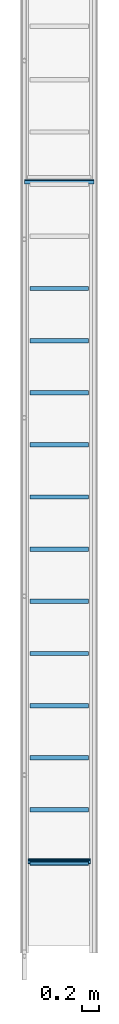
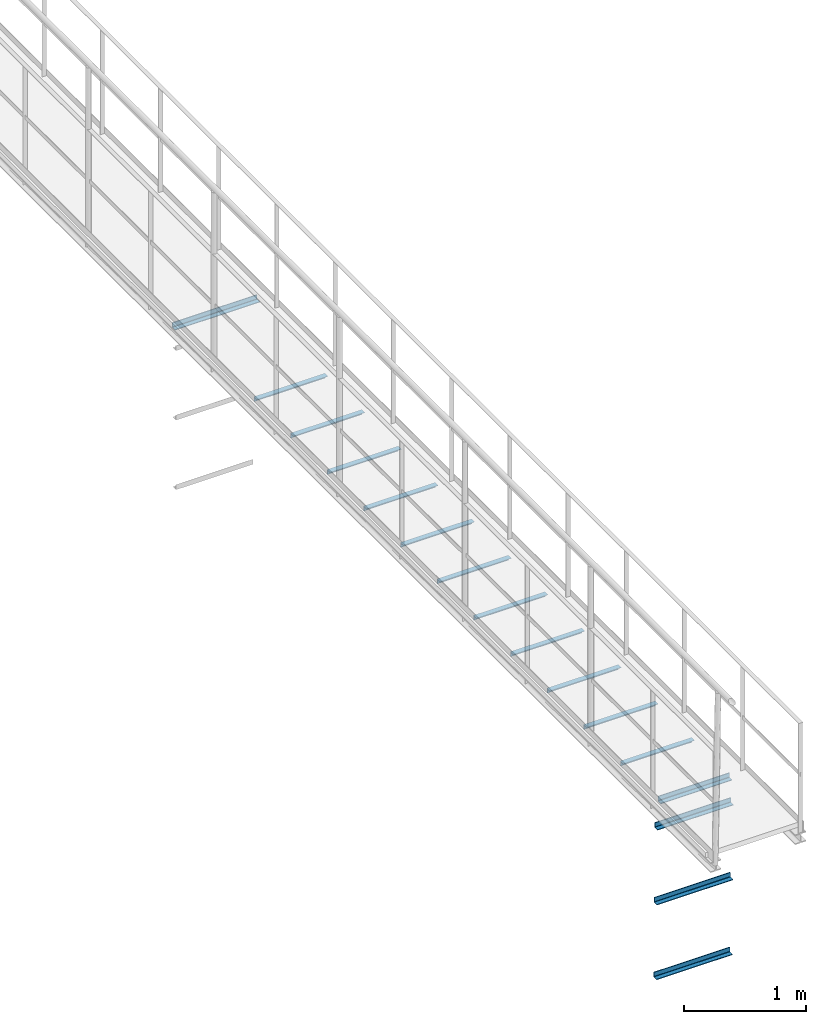
# One storey, part 4 of 6: 11 beams, 5 members.
"""IFC2X3 building model written with IfcOpenShell, lengths in metres."""

from ifc_helpers import new_model, entity, si_unit, converted_unit, derived_unit, direction, frame, frame_2d, origin, place, context, subcontext, project, spatial, polyline, circle_curve, parameter, trimmed, segment, composite_curve, outline, extrude, source, transform, mapped, material, type_object, type_shapes, element, save


model = new_model("IFC2X3")

# Units and contexts
model_context = context("Model", 3, precision=1e-05, world=origin(), true_north=direction((6.123233995736766e-17, 1.0)))
body_context = subcontext(model_context, "Body", "Model", "MODEL_VIEW")
ifc_project = project(units=[si_unit("LENGTHUNIT", "METRE"), converted_unit("PLANEANGLEUNIT", "DEGREE", entity("IfcPlaneAngleMeasure", 0.017453292519943278), si_unit("PLANEANGLEUNIT", "RADIAN"), dimensions=[0, 0, 0, 0, 0, 0, 0]), si_unit("AREAUNIT", "SQUARE_METRE"), derived_unit("THERMALTRANSMITTANCEUNIT", [(si_unit("MASSUNIT", "GRAM", prefix="KILO"), 1), (si_unit("THERMODYNAMICTEMPERATUREUNIT", "KELVIN"), -1), (si_unit("TIMEUNIT", "SECOND"), -3)])], contexts=[model_context])

# Site, building, storey
site_placement = place(None, origin())
site = spatial("IfcSite", under=ifc_project, at=site_placement, CompositionType="ELEMENT")
building_placement = place(site_placement, origin())
building = spatial("IfcBuilding", under=site, at=building_placement, CompositionType="ELEMENT")
storey_placement = place(building_placement, frame((0.0, 0.0, 8.8)))
storey = spatial("IfcBuildingStorey", under=building, at=storey_placement, Name="Piso 2.3", CompositionType="ELEMENT", Elevation=8.8)

# Members
ifc_material = material(Name="Metal - Steel - 345 MPa")
member_type_1 = type_object("IfcMemberType", Name="L-Angles:CAE50x5", PredefinedType="BRACE", material=ifc_material)
shared_shape_1 = source(origin(), body_context, "Body", "SweptSolid", [
    extrude(outline(composite_curve([segment(polyline([(-0.016428571428572104, -0.016428571428570952), (0.03357142857143008, -0.016428571428570952)]), True, "CONTINUOUS"), segment(trimmed(circle_curve(frame_2d((0.02857142857143008, -0.016428571428571702), x_axis=(1.0, 0.0)), 0.005), [parameter(5.088887490341632e-14)], [parameter(90.00000000000009)], True, "PARAMETER"), True, "CONTINUOUS"), segment(polyline([(0.02857142857143009, -0.011428571428571706), (-0.006428571428571976, -0.011428571428571706)]), True, "CONTINUOUS"), segment(trimmed(circle_curve(frame_2d((-0.006428571428571986, -0.006428571428571703), x_axis=(1.0, 0.0)), 0.005), [parameter(180.00000000000017)], [parameter(269.9999999999999)], True, "PARAMETER"), False, "CONTINUOUS"), segment(polyline([(-0.011428571428571985, -0.006428571428571719), (-0.011428571428571985, 0.02857142857142889)]), True, "CONTINUOUS"), segment(trimmed(circle_curve(frame_2d((-0.016428571428571986, 0.02857142857142889), x_axis=(1.0, 0.0)), 0.005), [parameter(0.0)], [parameter(90.00000000000024)], True, "PARAMETER"), True, "CONTINUOUS"), segment(polyline([(-0.016428571428572104, 0.03357142857142889), (-0.016428571428572104, -0.01642857142857095)]), True, "CONTINUOUS")], self_intersect=False)), frame((-0.337, -0.0024285714285723395, -0.0024285714285764517), z_axis=(1.0, 0.0, 0.0), x_axis=(0.0, -1.0, 0.0)), (0.0, 0.0, 1.0), 0.674),
])
type_shapes(member_type_1, [shared_shape_1])
member_1_placement = place(storey_placement, frame((4.1066971351921495, -3.3204777675637764, 0.0), z_axis=(0.0, 1.0, 0.0), x_axis=(1.0, 0.0, 0.0)))
element("IfcMember", 1, at=member_1_placement, inside=storey, type_object=member_type_1, material=ifc_material, Name="L-Angles:CAE50x5", ObjectType="L-Angles:CAE50x5", context=body_context, shape_type="MappedRepresentation", body=[
    mapped(shared_shape_1, transform((0.0, 0.0, 0.0), scale=1.0)),
])
member_type_2 = type_object("IfcMemberType", Name="L-Angles:CAE50x5", PredefinedType="BRACE", material=ifc_material)
shared_shape_2 = source(origin(), body_context, "Body", "SweptSolid", [
    extrude(outline(composite_curve([segment(polyline([(-0.016428571428572104, -0.016428571428570952), (0.03357142857143008, -0.016428571428570952)]), True, "CONTINUOUS"), segment(trimmed(circle_curve(frame_2d((0.02857142857143008, -0.016428571428571702), x_axis=(1.0, 0.0)), 0.005), [parameter(5.088887490341632e-14)], [parameter(90.00000000000009)], True, "PARAMETER"), True, "CONTINUOUS"), segment(polyline([(0.02857142857143009, -0.011428571428571706), (-0.006428571428571976, -0.011428571428571706)]), True, "CONTINUOUS"), segment(trimmed(circle_curve(frame_2d((-0.006428571428571986, -0.006428571428571703), x_axis=(1.0, 0.0)), 0.005), [parameter(180.00000000000017)], [parameter(269.9999999999999)], True, "PARAMETER"), False, "CONTINUOUS"), segment(polyline([(-0.011428571428571985, -0.006428571428571719), (-0.011428571428571985, 0.02857142857142889)]), True, "CONTINUOUS"), segment(trimmed(circle_curve(frame_2d((-0.016428571428571986, 0.02857142857142889), x_axis=(1.0, 0.0)), 0.005), [parameter(0.0)], [parameter(90.00000000000024)], True, "PARAMETER"), True, "CONTINUOUS"), segment(polyline([(-0.016428571428572104, 0.03357142857142889), (-0.016428571428572104, -0.01642857142857095)]), True, "CONTINUOUS")], self_intersect=False)), frame((-0.4, -0.0024285714285723395, -0.0024285714285764517), z_axis=(1.0, 0.0, 0.0), x_axis=(0.0, -1.0, 0.0)), (0.0, 0.0, 1.0), 0.8),
])
type_shapes(member_type_2, [shared_shape_2])
member_2_placement = place(storey_placement, frame((4.106697135192162, 4.519522232436223, 0.0), z_axis=(0.0, 1.0, 0.0), x_axis=(1.0, 0.0, 0.0)))
element("IfcMember", 2, at=member_2_placement, inside=storey, type_object=member_type_2, material=ifc_material, Name="L-Angles:CAE50x5", ObjectType="L-Angles:CAE50x5", context=body_context, shape_type="MappedRepresentation", body=[
    mapped(shared_shape_2, transform((0.0, 0.0, 0.0), scale=1.0)),
])

# Beams
beam_type = type_object("IfcBeamType", Name="L-Angles:CAE50x5", PredefinedType="BEAM")
beam_1_placement = place(storey_placement, frame((3.7066971351921265, -2.706477767563773, 0.0)))
element("IfcBeam", 3, at=beam_1_placement, inside=storey, type_object=beam_type, material=ifc_material, Name="L-Angles:CAE50x5", ObjectType="L-Angles:CAE50x5", context=body_context, shape_type="SweptSolid", body=[
    extrude(outline(composite_curve([segment(polyline([(-0.033571428571429786, -0.01642857142857166), (0.016428571428569683, -0.01642857142857166)]), True, "CONTINUOUS"), segment(polyline([(0.016428571428569683, -0.0164285714285722), (0.016428571428570224, 0.03357142857143051)]), True, "CONTINUOUS"), segment(trimmed(circle_curve(frame_2d((0.01642857142857017, 0.02857142857143002), x_axis=(0.0, 1.0)), 0.004999999999999386), [parameter(0.0)], [parameter(90.0000000000187)], True, "PARAMETER"), True, "CONTINUOUS"), segment(polyline([(0.011428571428571305, 0.02857142857142953), (0.011428571428570927, -0.006428571428572257)]), True, "CONTINUOUS"), segment(trimmed(circle_curve(frame_2d((0.00642857142857098, -0.006428571428572743), x_axis=(1.0, 0.0)), 0.004999999999999392), [parameter(269.9999999999813)], [parameter(0.0)], True, "PARAMETER"), False, "CONTINUOUS"), segment(polyline([(0.006428571428569843, -0.011428571428572148), (-0.028571428571430864, -0.011428571428571229)]), True, "CONTINUOUS"), segment(trimmed(circle_curve(frame_2d((-0.028571428571429833, -0.016428571428571716), x_axis=(0.0, 1.0)), 0.0049999999999998075), [parameter(0.0)], [parameter(90.00000000000009)], True, "PARAMETER"), True, "CONTINUOUS")], self_intersect=False)), frame((0.06300000000002301, -0.002428571428571418, -0.002428571428575208), z_axis=(1.0, 0.0, 0.0), x_axis=(0.0, 0.0, 1.0)), (0.0, 0.0, 1.0), 0.6740000000000007),
])
beam_2_placement = place(storey_placement, frame((3.706697135192128, -2.106477767563773, 0.0)))
element("IfcBeam", 4, at=beam_2_placement, inside=storey, type_object=beam_type, material=ifc_material, Name="L-Angles:CAE50x5", ObjectType="L-Angles:CAE50x5", context=body_context, shape_type="SweptSolid", body=[
    extrude(outline(composite_curve([segment(polyline([(-0.033571428571429605, -0.016428571428572025), (0.01642857142856986, -0.016428571428572025)]), True, "CONTINUOUS"), segment(polyline([(0.01642857142856986, -0.016428571428572025), (0.01642857142856986, 0.03357142857143015)]), True, "CONTINUOUS"), segment(trimmed(circle_curve(frame_2d((0.016428571428570942, 0.02857142857143047), x_axis=(0.0, 1.0)), 0.004999999999999608), [parameter(0.0)], [parameter(90.0000000000032)], True, "PARAMETER"), True, "CONTINUOUS"), segment(polyline([(0.011428571428570997, 0.028571428571430198), (0.011428571428570997, -0.006428571428571863)]), True, "CONTINUOUS"), segment(trimmed(circle_curve(frame_2d((0.006428571428569967, -0.006428571428572134), x_axis=(1.0, 0.0)), 0.004999999999999601), [parameter(269.9999999999968)], [parameter(0.0)], True, "PARAMETER"), False, "CONTINUOUS"), segment(polyline([(0.006428571428569967, -0.011428571428571808), (-0.02857142857143074, -0.011428571428571808)]), True, "CONTINUOUS"), segment(trimmed(circle_curve(frame_2d((-0.028571428571429656, -0.016428571428571483), x_axis=(0.0, 1.0)), 0.0049999999999996), [parameter(0.0)], [parameter(90.0000000000032)], True, "PARAMETER"), True, "CONTINUOUS")], self_intersect=False)), frame((0.06300000000002368, -0.0024285714285722303, -0.002428571428575208), z_axis=(1.0, 0.0, 0.0), x_axis=(0.0, 0.0, 1.0)), (0.0, 0.0, 1.0), 0.6740000000000007),
])
beam_3_placement = place(storey_placement, frame((3.7066971351921265, -1.5064777675637728, 0.0)))
element("IfcBeam", 5, at=beam_3_placement, inside=storey, type_object=beam_type, material=ifc_material, Name="L-Angles:CAE50x5", ObjectType="L-Angles:CAE50x5", context=body_context, shape_type="SweptSolid", body=[
    extrude(outline(composite_curve([segment(polyline([(-0.033571428571429605, -0.016428571428572025), (0.01642857142856986, -0.016428571428572025)]), True, "CONTINUOUS"), segment(polyline([(0.01642857142856986, -0.016428571428572025), (0.01642857142856986, 0.03357142857143015)]), True, "CONTINUOUS"), segment(trimmed(circle_curve(frame_2d((0.016428571428570942, 0.02857142857143047), x_axis=(0.0, 1.0)), 0.004999999999999608), [parameter(0.0)], [parameter(90.0000000000032)], True, "PARAMETER"), True, "CONTINUOUS"), segment(polyline([(0.011428571428570997, 0.028571428571430198), (0.011428571428570997, -0.006428571428571863)]), True, "CONTINUOUS"), segment(trimmed(circle_curve(frame_2d((0.006428571428569967, -0.006428571428572134), x_axis=(1.0, 0.0)), 0.004999999999999601), [parameter(269.9999999999968)], [parameter(0.0)], True, "PARAMETER"), False, "CONTINUOUS"), segment(polyline([(0.006428571428569967, -0.011428571428571808), (-0.02857142857143074, -0.011428571428571808)]), True, "CONTINUOUS"), segment(trimmed(circle_curve(frame_2d((-0.028571428571429656, -0.016428571428571483), x_axis=(0.0, 1.0)), 0.0049999999999996), [parameter(0.0)], [parameter(90.0000000000032)], True, "PARAMETER"), True, "CONTINUOUS")], self_intersect=False)), frame((0.06300000000002327, -0.0024285714285722303, -0.002428571428575208), z_axis=(1.0, 0.0, 0.0), x_axis=(0.0, 0.0, 1.0)), (0.0, 0.0, 1.0), 0.6740000000000007),
])
beam_4_placement = place(storey_placement, frame((3.7066971351921265, -0.9064777675637727, 0.0)))
element("IfcBeam", 6, at=beam_4_placement, inside=storey, type_object=beam_type, material=ifc_material, Name="L-Angles:CAE50x5", ObjectType="L-Angles:CAE50x5", context=body_context, shape_type="SweptSolid", body=[
    extrude(outline(composite_curve([segment(polyline([(-0.033571428571429564, -0.016428571428572115), (0.016428571428569905, -0.016428571428572115)]), True, "CONTINUOUS"), segment(polyline([(0.016428571428569905, -0.01642857142857198), (0.01642857142856977, 0.033571428571430056)]), True, "CONTINUOUS"), segment(trimmed(circle_curve(frame_2d((0.016428571428570866, 0.02857142857143065), x_axis=(0.0, 1.0)), 0.004999999999999499), [parameter(0.0)], [parameter(90.00000000000475)], True, "PARAMETER"), True, "CONTINUOUS"), segment(polyline([(0.011428571428570919, 0.02857142857143023), (0.011428571428571014, -0.006428571428571967)]), True, "CONTINUOUS"), segment(trimmed(circle_curve(frame_2d((0.006428571428569984, -0.006428571428572116), x_axis=(1.0, 0.0)), 0.004999999999999601), [parameter(269.9999999999968)], [parameter(0.0)], True, "PARAMETER"), False, "CONTINUOUS"), segment(polyline([(0.006428571428569998, -0.011428571428571791), (-0.028571428571430708, -0.011428571428572022)]), True, "CONTINUOUS"), segment(trimmed(circle_curve(frame_2d((-0.02857142857142961, -0.01642857142857156), x_axis=(0.0, 1.0)), 0.0049999999999995985), [parameter(0.0)], [parameter(90.0000000000063)], True, "PARAMETER"), True, "CONTINUOUS")], self_intersect=False)), frame((0.06300000000002287, -0.0024285714285723656, -0.002428571428575208), z_axis=(1.0, 0.0, 0.0), x_axis=(0.0, 0.0, 1.0)), (0.0, 0.0, 1.0), 0.6740000000000007),
])
beam_5_placement = place(storey_placement, frame((3.7066971351921265, -0.3064777675637727, 0.0)))
element("IfcBeam", 7, at=beam_5_placement, inside=storey, type_object=beam_type, material=ifc_material, Name="L-Angles:CAE50x5", ObjectType="L-Angles:CAE50x5", context=body_context, shape_type="SweptSolid", body=[
    extrude(outline(composite_curve([segment(polyline([(-0.03357142857142962, -0.0164285714285721), (0.01642857142856985, -0.016428571428572104)]), True, "CONTINUOUS"), segment(polyline([(0.01642857142856985, -0.016428571428572136), (0.016428571428569884, 0.03357142857143006)]), True, "CONTINUOUS"), segment(trimmed(circle_curve(frame_2d((0.016428571428570963, 0.02857142857143039), x_axis=(0.0, 1.0)), 0.0049999999999996774), [parameter(0.0)], [parameter(90.00000000000396)], True, "PARAMETER"), True, "CONTINUOUS"), segment(polyline([(0.011428571428571016, 0.028571428571430055), (0.011428571428570991, -0.006428571428572006)]), True, "CONTINUOUS"), segment(trimmed(circle_curve(frame_2d((0.006428571428569963, -0.006428571428572374), x_axis=(1.0, 0.0)), 0.004999999999999638), [parameter(269.9999999999956)], [parameter(0.0)], True, "PARAMETER"), False, "CONTINUOUS"), segment(polyline([(0.006428571428569959, -0.011428571428572017), (-0.028571428571430746, -0.01142857142857196)]), True, "CONTINUOUS"), segment(trimmed(circle_curve(frame_2d((-0.028571428571429667, -0.016428571428571667), x_axis=(0.0, 1.0)), 0.004999999999999694), [parameter(0.0)], [parameter(90.00000000000553)], True, "PARAMETER"), True, "CONTINUOUS")], self_intersect=False)), frame((0.06300000000002301, -0.0024285714285723656, -0.002428571428575208), z_axis=(1.0, 0.0, 0.0), x_axis=(0.0, 0.0, 1.0)), (0.0, 0.0, 1.0), 0.6740000000000007),
])
beam_6_placement = place(storey_placement, frame((3.7066971351921265, 0.2935222324362273, 0.0)))
element("IfcBeam", 8, at=beam_6_placement, inside=storey, type_object=beam_type, material=ifc_material, Name="L-Angles:CAE50x5", ObjectType="L-Angles:CAE50x5", context=body_context, shape_type="SweptSolid", body=[
    extrude(outline(composite_curve([segment(polyline([(-0.033571428571429605, -0.01642857142857216), (0.01642857142856986, -0.01642857142857216)]), True, "CONTINUOUS"), segment(polyline([(0.01642857142856986, -0.01642857142857216), (0.01642857142856986, 0.03357142857143004)]), True, "CONTINUOUS"), segment(trimmed(circle_curve(frame_2d((0.016428571428570942, 0.028571428571430434), x_axis=(0.0, 1.0)), 0.004999999999999635), [parameter(0.0)], [parameter(90.00000000000436)], True, "PARAMETER"), True, "CONTINUOUS"), segment(polyline([(0.011428571428570997, 0.028571428571430062), (0.011428571428570997, -0.006428571428571998)]), True, "CONTINUOUS"), segment(trimmed(circle_curve(frame_2d((0.006428571428569967, -0.0064285714285723695), x_axis=(1.0, 0.0)), 0.004999999999999638), [parameter(269.9999999999956)], [parameter(0.0)], True, "PARAMETER"), False, "CONTINUOUS"), segment(polyline([(0.006428571428569967, -0.011428571428572011), (-0.02857142857143074, -0.011428571428571978)]), True, "CONTINUOUS"), segment(trimmed(circle_curve(frame_2d((-0.028571428571429656, -0.016428571428571688), x_axis=(0.0, 1.0)), 0.004999999999999714), [parameter(0.0)], [parameter(90.00000000000553)], True, "PARAMETER"), True, "CONTINUOUS")], self_intersect=False)), frame((0.06300000000002313, -0.0024285714285723656, -0.002428571428575208), z_axis=(1.0, 0.0, 0.0), x_axis=(0.0, 0.0, 1.0)), (0.0, 0.0, 1.0), 0.6740000000000007),
])
beam_7_placement = place(storey_placement, frame((3.7066971351921265, 0.8935222324362274, 0.0)))
element("IfcBeam", 9, at=beam_7_placement, inside=storey, type_object=beam_type, material=ifc_material, Name="L-Angles:CAE50x5", ObjectType="L-Angles:CAE50x5", context=body_context, shape_type="SweptSolid", body=[
    extrude(outline(composite_curve([segment(polyline([(-0.033571428571429564, -0.016428571428572115), (0.016428571428569905, -0.016428571428572115)]), True, "CONTINUOUS"), segment(polyline([(0.016428571428569905, -0.01642857142857198), (0.01642857142856977, 0.033571428571430056)]), True, "CONTINUOUS"), segment(trimmed(circle_curve(frame_2d((0.016428571428570866, 0.02857142857143065), x_axis=(0.0, 1.0)), 0.004999999999999499), [parameter(0.0)], [parameter(90.00000000000475)], True, "PARAMETER"), True, "CONTINUOUS"), segment(polyline([(0.011428571428570919, 0.02857142857143023), (0.011428571428571014, -0.006428571428571967)]), True, "CONTINUOUS"), segment(trimmed(circle_curve(frame_2d((0.006428571428569984, -0.006428571428572116), x_axis=(1.0, 0.0)), 0.004999999999999601), [parameter(269.9999999999968)], [parameter(0.0)], True, "PARAMETER"), False, "CONTINUOUS"), segment(polyline([(0.006428571428569998, -0.011428571428571791), (-0.028571428571430708, -0.011428571428572022)]), True, "CONTINUOUS"), segment(trimmed(circle_curve(frame_2d((-0.02857142857142961, -0.01642857142857156), x_axis=(0.0, 1.0)), 0.0049999999999995985), [parameter(0.0)], [parameter(90.0000000000063)], True, "PARAMETER"), True, "CONTINUOUS")], self_intersect=False)), frame((0.06300000000002327, -0.0024285714285723656, -0.002428571428575208), z_axis=(1.0, 0.0, 0.0), x_axis=(0.0, 0.0, 1.0)), (0.0, 0.0, 1.0), 0.6740000000000007),
])
beam_8_placement = place(storey_placement, frame((3.7066971351921265, 1.4935222324362274, 0.0)))
element("IfcBeam", 10, at=beam_8_placement, inside=storey, type_object=beam_type, material=ifc_material, Name="L-Angles:CAE50x5", ObjectType="L-Angles:CAE50x5", context=body_context, shape_type="SweptSolid", body=[
    extrude(outline(composite_curve([segment(polyline([(-0.033571428571429605, -0.016428571428572295), (0.01642857142856986, -0.016428571428572295)]), True, "CONTINUOUS"), segment(polyline([(0.01642857142856986, -0.016428571428572295), (0.01642857142856986, 0.033571428571429876)]), True, "CONTINUOUS"), segment(trimmed(circle_curve(frame_2d((0.016428571428570942, 0.028571428571430198), x_axis=(0.0, 1.0)), 0.004999999999999608), [parameter(0.0)], [parameter(90.0000000000032)], True, "PARAMETER"), True, "CONTINUOUS"), segment(polyline([(0.011428571428570997, 0.028571428571429927), (0.011428571428570997, -0.006428571428572134)]), True, "CONTINUOUS"), segment(trimmed(circle_curve(frame_2d((0.006428571428569967, -0.006428571428572404), x_axis=(1.0, 0.0)), 0.004999999999999601), [parameter(269.9999999999968)], [parameter(0.0)], True, "PARAMETER"), False, "CONTINUOUS"), segment(polyline([(0.006428571428569967, -0.011428571428572079), (-0.02857142857143074, -0.011428571428572079)]), True, "CONTINUOUS"), segment(trimmed(circle_curve(frame_2d((-0.028571428571429656, -0.016428571428571754), x_axis=(0.0, 1.0)), 0.0049999999999996), [parameter(0.0)], [parameter(90.0000000000032)], True, "PARAMETER"), True, "CONTINUOUS")], self_intersect=False)), frame((0.06300000000002287, -0.002428571428572501, -0.002428571428575208), z_axis=(1.0, 0.0, 0.0), x_axis=(0.0, 0.0, 1.0)), (0.0, 0.0, 1.0), 0.6740000000000007),
])
beam_9_placement = place(storey_placement, frame((3.7066971351921265, 2.0935222324362273, 0.0)))
element("IfcBeam", 11, at=beam_9_placement, inside=storey, type_object=beam_type, material=ifc_material, Name="L-Angles:CAE50x5", ObjectType="L-Angles:CAE50x5", context=body_context, shape_type="SweptSolid", body=[
    extrude(outline(composite_curve([segment(polyline([(-0.033571428571429605, -0.016428571428572295), (0.01642857142856986, -0.016428571428572295)]), True, "CONTINUOUS"), segment(polyline([(0.01642857142856986, -0.016428571428572295), (0.01642857142856986, 0.033571428571429876)]), True, "CONTINUOUS"), segment(trimmed(circle_curve(frame_2d((0.016428571428570942, 0.028571428571430198), x_axis=(0.0, 1.0)), 0.004999999999999608), [parameter(0.0)], [parameter(90.0000000000032)], True, "PARAMETER"), True, "CONTINUOUS"), segment(polyline([(0.011428571428570997, 0.028571428571429927), (0.011428571428570997, -0.006428571428572134)]), True, "CONTINUOUS"), segment(trimmed(circle_curve(frame_2d((0.006428571428569967, -0.006428571428572404), x_axis=(1.0, 0.0)), 0.004999999999999601), [parameter(269.9999999999968)], [parameter(0.0)], True, "PARAMETER"), False, "CONTINUOUS"), segment(polyline([(0.006428571428569967, -0.011428571428572079), (-0.02857142857143074, -0.011428571428572079)]), True, "CONTINUOUS"), segment(trimmed(circle_curve(frame_2d((-0.028571428571429656, -0.016428571428571754), x_axis=(0.0, 1.0)), 0.0049999999999996), [parameter(0.0)], [parameter(90.0000000000032)], True, "PARAMETER"), True, "CONTINUOUS")], self_intersect=False)), frame((0.06300000000002301, -0.002428571428572501, -0.002428571428575208), z_axis=(1.0, 0.0, 0.0), x_axis=(0.0, 0.0, 1.0)), (0.0, 0.0, 1.0), 0.6740000000000007),
])
beam_10_placement = place(storey_placement, frame((3.7066971351921265, 2.6935222324362273, 0.0)))
element("IfcBeam", 12, at=beam_10_placement, inside=storey, type_object=beam_type, material=ifc_material, Name="L-Angles:CAE50x5", ObjectType="L-Angles:CAE50x5", context=body_context, shape_type="SweptSolid", body=[
    extrude(outline(composite_curve([segment(polyline([(-0.033571428571429786, -0.01642857142857166), (0.016428571428569683, -0.01642857142857166)]), True, "CONTINUOUS"), segment(polyline([(0.016428571428569683, -0.0164285714285722), (0.016428571428570224, 0.03357142857143051)]), True, "CONTINUOUS"), segment(trimmed(circle_curve(frame_2d((0.01642857142857017, 0.02857142857143002), x_axis=(0.0, 1.0)), 0.004999999999999386), [parameter(0.0)], [parameter(90.0000000000187)], True, "PARAMETER"), True, "CONTINUOUS"), segment(polyline([(0.011428571428571305, 0.02857142857142953), (0.011428571428570927, -0.006428571428572257)]), True, "CONTINUOUS"), segment(trimmed(circle_curve(frame_2d((0.00642857142857098, -0.006428571428572743), x_axis=(1.0, 0.0)), 0.004999999999999392), [parameter(269.9999999999813)], [parameter(0.0)], True, "PARAMETER"), False, "CONTINUOUS"), segment(polyline([(0.006428571428569843, -0.011428571428572148), (-0.028571428571430864, -0.011428571428571229)]), True, "CONTINUOUS"), segment(trimmed(circle_curve(frame_2d((-0.028571428571429833, -0.016428571428571716), x_axis=(0.0, 1.0)), 0.0049999999999998075), [parameter(0.0)], [parameter(90.00000000000009)], True, "PARAMETER"), True, "CONTINUOUS")], self_intersect=False)), frame((0.06300000000002313, -0.002428571428571418, -0.002428571428575208), z_axis=(1.0, 0.0, 0.0), x_axis=(0.0, 0.0, 1.0)), (0.0, 0.0, 1.0), 0.6740000000000007),
])
beam_11_placement = place(storey_placement, frame((3.7066971351921265, 3.2935222324362274, 0.0)))
element("IfcBeam", 13, at=beam_11_placement, inside=storey, type_object=beam_type, material=ifc_material, Name="L-Angles:CAE50x5", ObjectType="L-Angles:CAE50x5", context=body_context, shape_type="SweptSolid", body=[
    extrude(outline(composite_curve([segment(polyline([(-0.033571428571429786, -0.01642857142857112), (0.016428571428569683, -0.01642857142857112)]), True, "CONTINUOUS"), segment(polyline([(0.016428571428569683, -0.01642857142857166), (0.016428571428570224, 0.03357142857143105)]), True, "CONTINUOUS"), segment(trimmed(circle_curve(frame_2d((0.01642857142857017, 0.028571428571430562), x_axis=(0.0, 1.0)), 0.004999999999999386), [parameter(0.0)], [parameter(90.0000000000187)], True, "PARAMETER"), True, "CONTINUOUS"), segment(polyline([(0.011428571428571305, 0.028571428571430073), (0.011428571428570927, -0.006428571428571715)]), True, "CONTINUOUS"), segment(trimmed(circle_curve(frame_2d((0.00642857142857098, -0.006428571428572201), x_axis=(1.0, 0.0)), 0.004999999999999392), [parameter(269.9999999999813)], [parameter(0.0)], True, "PARAMETER"), False, "CONTINUOUS"), segment(polyline([(0.006428571428569843, -0.011428571428571607), (-0.028571428571430864, -0.011428571428570686)]), True, "CONTINUOUS"), segment(trimmed(circle_curve(frame_2d((-0.028571428571429833, -0.016428571428571175), x_axis=(0.0, 1.0)), 0.0049999999999998075), [parameter(0.0)], [parameter(90.00000000000009)], True, "PARAMETER"), True, "CONTINUOUS")], self_intersect=False)), frame((0.06300000000002327, -0.0024285714285708763, -0.002428571428575208), z_axis=(1.0, 0.0, 0.0), x_axis=(0.0, 0.0, 1.0)), (0.0, 0.0, 1.0), 0.6740000000000007),
])

# Members
member_type_3 = type_object("IfcMemberType", Name="L-Angles:CAE50x5", PredefinedType="BRACE", material=ifc_material)
shared_shape_3 = source(origin(), body_context, "Body", "SweptSolid", [
    extrude(outline(composite_curve([segment(polyline([(-0.016428571428572104, -0.016428571428570952), (0.03357142857143008, -0.016428571428570952)]), True, "CONTINUOUS"), segment(trimmed(circle_curve(frame_2d((0.02857142857143008, -0.016428571428571702), x_axis=(1.0, 0.0)), 0.005), [parameter(5.088887490341632e-14)], [parameter(90.00000000000009)], True, "PARAMETER"), True, "CONTINUOUS"), segment(polyline([(0.02857142857143009, -0.011428571428571706), (-0.006428571428571976, -0.011428571428571706)]), True, "CONTINUOUS"), segment(trimmed(circle_curve(frame_2d((-0.006428571428571986, -0.006428571428571703), x_axis=(1.0, 0.0)), 0.005), [parameter(180.00000000000017)], [parameter(269.9999999999999)], True, "PARAMETER"), False, "CONTINUOUS"), segment(polyline([(-0.011428571428571985, -0.006428571428571719), (-0.011428571428571985, 0.02857142857142889)]), True, "CONTINUOUS"), segment(trimmed(circle_curve(frame_2d((-0.016428571428571986, 0.02857142857142889), x_axis=(1.0, 0.0)), 0.005), [parameter(0.0)], [parameter(90.00000000000024)], True, "PARAMETER"), True, "CONTINUOUS"), segment(polyline([(-0.016428571428572104, 0.03357142857142889), (-0.016428571428572104, -0.01642857142857095)]), True, "CONTINUOUS")], self_intersect=False)), frame((-0.3590000000000001, -0.0024285714285723395, -0.0024285714285764517), z_axis=(1.0, 0.0, 0.0), x_axis=(0.0, -1.0, 0.0)), (0.0, 0.0, 1.0), 0.718),
])
type_shapes(member_type_3, [shared_shape_3])
member_3_placement = place(storey_placement, frame((4.106697134264632, -3.3036035422499084, -0.2659852475081165), z_axis=(-6.453694712071691e-06, 1.0, 0.0), x_axis=(1.0, 6.453694712071678e-06, 6.62512511823739e-08)))
element("IfcMember", 14, at=member_3_placement, inside=storey, type_object=member_type_3, material=ifc_material, Name="L-Angles:CAE50x5", ObjectType="L-Angles:CAE50x5", context=body_context, shape_type="MappedRepresentation", body=[
    mapped(shared_shape_3, transform((0.0, 0.0, 0.0), scale=1.0)),
])
member_type_4 = type_object("IfcMemberType", Name="L-Angles:CAE50x5", PredefinedType="BRACE", material=ifc_material)
shared_shape_4 = source(origin(), body_context, "Body", "SweptSolid", [
    extrude(outline(composite_curve([segment(polyline([(-0.016428571428572104, -0.016428571428570952), (0.03357142857143008, -0.016428571428570952)]), True, "CONTINUOUS"), segment(trimmed(circle_curve(frame_2d((0.02857142857143008, -0.016428571428571702), x_axis=(1.0, 0.0)), 0.005), [parameter(5.088887490341632e-14)], [parameter(90.00000000000009)], True, "PARAMETER"), True, "CONTINUOUS"), segment(polyline([(0.02857142857143009, -0.011428571428571706), (-0.006428571428571976, -0.011428571428571706)]), True, "CONTINUOUS"), segment(trimmed(circle_curve(frame_2d((-0.006428571428571986, -0.006428571428571703), x_axis=(1.0, 0.0)), 0.005), [parameter(180.00000000000017)], [parameter(269.9999999999999)], True, "PARAMETER"), False, "CONTINUOUS"), segment(polyline([(-0.011428571428571985, -0.006428571428571719), (-0.011428571428571985, 0.02857142857142889)]), True, "CONTINUOUS"), segment(trimmed(circle_curve(frame_2d((-0.016428571428571986, 0.02857142857142889), x_axis=(1.0, 0.0)), 0.005), [parameter(0.0)], [parameter(90.00000000000024)], True, "PARAMETER"), True, "CONTINUOUS"), segment(polyline([(-0.016428571428572104, 0.03357142857142889), (-0.016428571428572104, -0.01642857142857095)]), True, "CONTINUOUS")], self_intersect=False)), frame((-0.3590000000000001, -0.0024285714285723395, -0.0024285714285764517), z_axis=(1.0, 0.0, 0.0), x_axis=(0.0, -1.0, 0.0)), (0.0, 0.0, 1.0), 0.718),
])
type_shapes(member_type_4, [shared_shape_4])
member_4_placement = place(storey_placement, frame((4.106697129282537, -3.288164846278495, -1.7699060055517062), z_axis=(-4.1119254848843184e-05, 1.0, 0.0), x_axis=(1.0, 4.111925484883952e-05, 4.2211510999669866e-07)))
element("IfcMember", 15, at=member_4_placement, inside=storey, type_object=member_type_4, material=ifc_material, Name="L-Angles:CAE50x5", ObjectType="L-Angles:CAE50x5", context=body_context, shape_type="MappedRepresentation", body=[
    mapped(shared_shape_4, transform((0.0, 0.0, 0.0), scale=1.0)),
])
member_type_5 = type_object("IfcMemberType", Name="L-Angles:CAE50x5", PredefinedType="BRACE", material=ifc_material)
shared_shape_5 = source(origin(), body_context, "Body", "SweptSolid", [
    extrude(outline(composite_curve([segment(polyline([(-0.016428571428572104, -0.016428571428570952), (0.03357142857143008, -0.016428571428570952)]), True, "CONTINUOUS"), segment(trimmed(circle_curve(frame_2d((0.02857142857143008, -0.016428571428571702), x_axis=(1.0, 0.0)), 0.005), [parameter(5.088887490341632e-14)], [parameter(90.00000000000009)], True, "PARAMETER"), True, "CONTINUOUS"), segment(polyline([(0.02857142857143009, -0.011428571428571706), (-0.006428571428571976, -0.011428571428571706)]), True, "CONTINUOUS"), segment(trimmed(circle_curve(frame_2d((-0.006428571428571986, -0.006428571428571703), x_axis=(1.0, 0.0)), 0.005), [parameter(180.00000000000017)], [parameter(269.9999999999999)], True, "PARAMETER"), False, "CONTINUOUS"), segment(polyline([(-0.011428571428571985, -0.006428571428571719), (-0.011428571428571985, 0.02857142857142889)]), True, "CONTINUOUS"), segment(trimmed(circle_curve(frame_2d((-0.016428571428571986, 0.02857142857142889), x_axis=(1.0, 0.0)), 0.005), [parameter(0.0)], [parameter(90.00000000000024)], True, "PARAMETER"), True, "CONTINUOUS"), segment(polyline([(-0.016428571428572104, 0.03357142857142889), (-0.016428571428572104, -0.01642857142857095)]), True, "CONTINUOUS")], self_intersect=False)), frame((-0.3590000000000001, -0.0024285714285723395, -0.0024285714285764517), z_axis=(1.0, 0.0, 0.0), x_axis=(0.0, -1.0, 0.0)), (0.0, 0.0, 1.0), 0.718),
])
type_shapes(member_type_5, [shared_shape_5])
member_5_placement = place(storey_placement, frame((4.1066971317735845, -3.295884194264158, -1.0179456265299107), z_axis=(-2.3786474791176527e-05, 1.0, 0.0), x_axis=(1.0, 2.3786474791175816e-05, 2.441831806995861e-07)))
element("IfcMember", 16, at=member_5_placement, inside=storey, type_object=member_type_5, material=ifc_material, Name="L-Angles:CAE50x5", ObjectType="L-Angles:CAE50x5", context=body_context, shape_type="MappedRepresentation", body=[
    mapped(shared_shape_5, transform((0.0, 0.0, 0.0), scale=1.0)),
])

save(model, "model.ifc")
